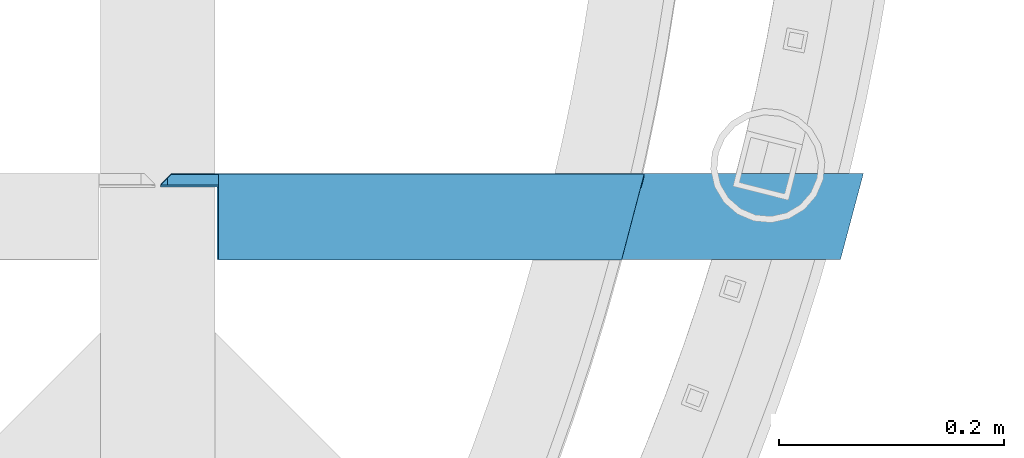
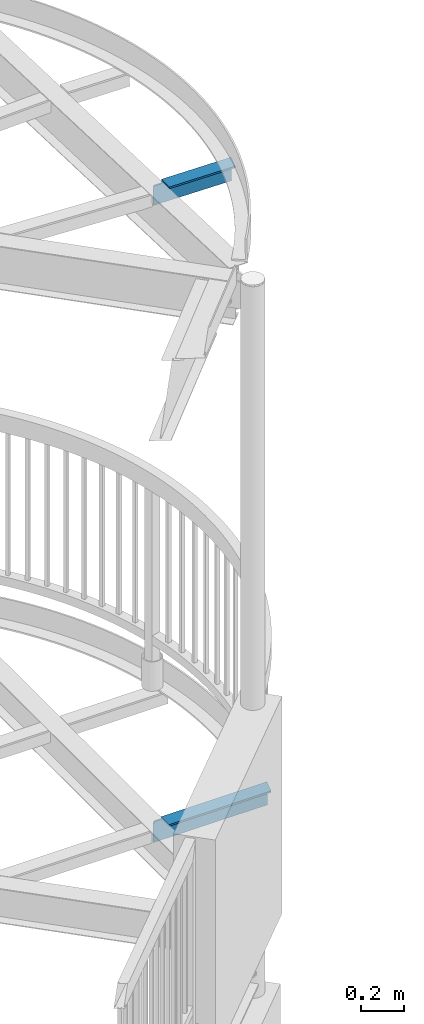
# One storey, part 525 of 975: 2 beams.
"""IFC2X3 building model written with IfcOpenShell, lengths in millimetres."""

import ifcopenshell
import ifcopenshell.guid

model = None  # the IFC model being written
_history = None  # IfcOwnerHistory: only IFC2X3 demands one
_inside = {}  # id of a spatial element -> (the spatial element, [elements in it])
_under = {}  # id of a project, library or spatial element -> (it, [spatial elements below it])
_declared = {}  # id of a project -> (the project, [libraries it declares])
_typed = {}  # id of a type object -> (the type object, [elements of that type])
_made_of = {}  # id of a material, layer set ... -> (it, [elements and type objects made of it])


def new_model(schema):
    """Start an empty IFC model of exactly this schema.

    Asked for "IFC4X3", IfcOpenShell would pick the latest addendum, in which some entities
    have other attributes; the version numbers below select the first issue.
    IFC2X3 requires an IfcOwnerHistory on every rooted entity: one is made here for all.
    """
    global model, _history
    if schema == "IFC4X3":
        model = ifcopenshell.file(schema_version=(4, 3, 0, 0))
    else:
        model = ifcopenshell.file(schema=schema)
    _inside.clear()
    _under.clear()
    _declared.clear()
    _typed.clear()
    _made_of.clear()
    _history = None
    if model.schema == "IFC2X3":
        org = make("IfcOrganization", Name="unknown")
        user = make(
            "IfcPersonAndOrganization",
            ThePerson=make("IfcPerson", FamilyName="unknown"),
            TheOrganization=org,
        )
        app = make(
            "IfcApplication",
            ApplicationDeveloper=org,
            Version="unknown",
            ApplicationFullName="unknown",
            ApplicationIdentifier="unknown",
        )
        _history = make(
            "IfcOwnerHistory",
            OwningUser=user,
            OwningApplication=app,
            ChangeAction="ADDED",
            CreationDate=0,
        )
    return model


def make(cls, **values):
    """One entity of the class cls with the attributes given. An attribute that is None is left unset."""
    return model.create_entity(
        cls, **{name: value for name, value in values.items() if value is not None}
    )


def rooted(cls, **values):
    """An entity with a GlobalId (a new one), such as an element, a storey or a relation."""
    return make(cls, GlobalId=ifcopenshell.guid.new(), OwnerHistory=_history, **values)


def si_unit(unit_type, name, prefix=None):
    """IfcSIUnit, for example si_unit("LENGTHUNIT", "METRE", prefix="MILLI")."""
    return make("IfcSIUnit", UnitType=unit_type, Prefix=prefix, Name=name)


def assignment(units):
    """IfcUnitAssignment: the units of a project."""
    return None if units is None else make("IfcUnitAssignment", Units=units)


def point(xyz):
    """IfcCartesianPoint."""
    return None if xyz is None else make("IfcCartesianPoint", Coordinates=xyz)


def direction(xyz):
    """IfcDirection."""
    return None if xyz is None else make("IfcDirection", DirectionRatios=xyz)


def frame(location, z_axis=None, x_axis=None):
    """IfcAxis2Placement3D, a coordinate frame: its origin and axes. An axis left out is left unset."""
    return make(
        "IfcAxis2Placement3D",
        Location=point(location),
        Axis=direction(z_axis),
        RefDirection=direction(x_axis),
    )


def origin_with_axes():
    """The frame at (0, 0, 0) with the z axis (0, 0, 1) and the x axis (1, 0, 0) written out."""
    return frame((0.0, 0.0, 0.0), z_axis=(0.0, 0.0, 1.0), x_axis=(1.0, 0.0, 0.0))


def place(relative_to, where):
    """IfcLocalPlacement: puts the frame where relative to a parent placement (None: the world)."""
    return make(
        "IfcLocalPlacement", PlacementRelTo=relative_to, RelativePlacement=where
    )


def context(
    kind, dimensions, precision=None, world=None, true_north=None, identifier=None
):
    """IfcGeometricRepresentationContext, for example the 3D "Model" context."""
    return make(
        "IfcGeometricRepresentationContext",
        ContextIdentifier=identifier,
        ContextType=kind,
        CoordinateSpaceDimension=dimensions,
        Precision=precision,
        WorldCoordinateSystem=world,
        TrueNorth=true_north,
    )


def subcontext(parent, identifier, kind, view, scale=None):
    """IfcGeometricRepresentationSubContext, for example "Body" below "Model"."""
    return make(
        "IfcGeometricRepresentationSubContext",
        ContextIdentifier=identifier,
        ContextType=kind,
        ParentContext=parent,
        TargetScale=scale,
        TargetView=view,
    )


def project(units=None, contexts=None):
    """IfcProject with its units and contexts."""
    return rooted(
        "IfcProject",
        Name="project",
        RepresentationContexts=contexts,
        UnitsInContext=assignment(units),
    )


def spatial(cls, under=None, at=None, **own):
    """A site, building, storey or space (cls), placed at a placement, below another one or the project."""
    s = rooted(cls, ObjectPlacement=at, **own)
    if under is not None:
        _under.setdefault(under.id(), (under, []))[1].append(s)
    return s


def faces_of(points, faces, orient=None, outer=None):
    """IfcFace entities. A face is a list of loops; a loop is a list of indices into points, from 0.

    orient and outer hold one flag for each loop. By default every Orientation is true, the
    first loop of a face is its IfcFaceOuterBound and the others are IfcFaceBound.
    """
    made = []
    for i, loops in enumerate(faces):
        bounds = []
        for j, loop in enumerate(loops):
            is_outer = j == 0 if outer is None else outer[i][j]
            bounds.append(
                make(
                    "IfcFaceOuterBound" if is_outer else "IfcFaceBound",
                    Bound=make("IfcPolyLoop", Polygon=[points[k] for k in loop]),
                    Orientation=True if orient is None else orient[i][j],
                )
            )
        made.append(make("IfcFace", Bounds=bounds))
    return made


def faceted_brep(points, faces, orient=None, outer=None, voids=None):
    """IfcFacetedBrep: a solid bounded by flat faces; with voids (closed shells), ...WithVoids."""
    shared = [point(p) for p in points]
    hull = make("IfcClosedShell", CfsFaces=faces_of(shared, faces, orient, outer))
    if voids is None:
        return make("IfcFacetedBrep", Outer=hull)
    return make(
        "IfcFacetedBrepWithVoids",
        Outer=hull,
        Voids=[
            make(cls, CfsFaces=faces_of(shared, fs, o, b)) for cls, fs, o, b in voids
        ],
    )


def shape(context_of_items, identifier, shape_type, items):
    """IfcShapeRepresentation: the items that make up one representation, for example the "Body"."""
    return make(
        "IfcShapeRepresentation",
        ContextOfItems=context_of_items,
        RepresentationIdentifier=identifier,
        RepresentationType=shape_type,
        Items=items,
    )


def material(Name=None, Category=None):
    """IfcMaterial."""
    return make("IfcMaterial", Name=Name, Category=Category)


def made_of(thing, what):
    """Note that an element or type object is made of a material, layer set ...; save() writes the relation."""
    if what is not None:
        _made_of.setdefault(what.id(), (what, []))[1].append(thing)
    return thing


def type_object(cls, material=None, **own):
    """A type object (cls), such as IfcWallType, which elements share."""
    return made_of(rooted(cls, **own), material)


def element(
    cls,
    number,
    at=None,
    inside=None,
    cuts=None,
    type_object=None,
    material=None,
    context=None,
    identifier="Body",
    shape_type=None,
    held_by="IfcProductDefinitionShape",
    body=None,
    shapes=None,
    **own,
):
    """One element of the class cls, such as IfcWall. Its Tag is "e" and its number.

    at: its placement. inside: the storey or other place that contains it. cuts: it is an
    opening in that element (IfcRelVoidsElement). A single representation is given by context,
    identifier, shape_type and body (its items); several are given by shapes. held_by: the class
    of the entity that holds the representations. save() writes the other relations.
    """
    e = rooted(cls, Tag="e%d" % number, ObjectPlacement=at, **own)
    if body is not None:
        shapes = [shape(context, identifier, shape_type, body)]
    if shapes is not None:
        e.Representation = make(held_by, Representations=shapes)
    if inside is not None:
        _inside.setdefault(inside.id(), (inside, []))[1].append(e)
    if cuts is not None:
        rooted(
            "IfcRelVoidsElement", RelatingBuildingElement=cuts, RelatedOpeningElement=e
        )
    if type_object is not None:
        _typed.setdefault(type_object.id(), (type_object, []))[1].append(e)
    return made_of(e, material)


def aggregate(whole, parts):
    """IfcRelAggregates: a whole, such as a stair, and the parts it consists of."""
    return rooted("IfcRelAggregates", RelatingObject=whole, RelatedObjects=parts)


def save(model, path):
    """Write the relations noted so far, then the file.

    IfcRelAggregates (storeys below a building ...), IfcRelContainedInSpatialStructure (elements
    in a storey), IfcRelDefinesByType, IfcRelAssociatesMaterial and IfcRelDeclares: one each for
    every whole, place, type object, material and project.
    """
    for whole, parts in _under.values():
        aggregate(whole, parts)
    for where, things in _inside.values():
        rooted(
            "IfcRelContainedInSpatialStructure",
            RelatedElements=things,
            RelatingStructure=where,
        )
    for kind, things in _typed.values():
        rooted("IfcRelDefinesByType", RelatedObjects=things, RelatingType=kind)
    for what, things in _made_of.values():
        rooted("IfcRelAssociatesMaterial", RelatedObjects=things, RelatingMaterial=what)
    for by, libraries in _declared.values():
        rooted("IfcRelDeclares", RelatingContext=by, RelatedDefinitions=libraries)
    model.write(path)


model = new_model("IFC2X3")

# Units and contexts
model_context = context("Model", 3, precision=1e-05, world=origin_with_axes())
body_context = subcontext(model_context, "Body", "Model", "MODEL_VIEW")
ifc_project = project(units=[si_unit("LENGTHUNIT", "METRE", prefix="MILLI"), si_unit("AREAUNIT", "SQUARE_METRE"), si_unit("VOLUMEUNIT", "CUBIC_METRE"), si_unit("MASSUNIT", "GRAM", prefix="KILO"), si_unit("TIMEUNIT", "SECOND"), si_unit("PLANEANGLEUNIT", "RADIAN"), si_unit("SOLIDANGLEUNIT", "STERADIAN"), si_unit("THERMODYNAMICTEMPERATUREUNIT", "DEGREE_CELSIUS"), si_unit("LUMINOUSINTENSITYUNIT", "LUMEN")], contexts=[model_context])

# Site, building, storey
site_placement = place(None, origin_with_axes())
site = spatial("IfcSite", under=ifc_project, at=site_placement, CompositionType="ELEMENT")
building_placement = place(site_placement, origin_with_axes())
building = spatial("IfcBuilding", under=site, at=building_placement, Name="Undefined", CompositionType="ELEMENT")
storey_placement = place(building_placement, origin_with_axes())
storey = spatial("IfcBuildingStorey", under=building, at=storey_placement, Name="Undefined", CompositionType="ELEMENT", Elevation=0.0)

# Beams
ifc_material = material(Name="STEEL/A36")
beam_type = type_object("IfcBeamType", Name="L5X3X3/8", PredefinedType="NOTDEFINED")
beam_1_placement = place(storey_placement, frame((36163.6763496532, 11155.2515974381, 3873.5), z_axis=(0.0, 0.0, -1.0), x_axis=(-0.999999999999998, 6.90000001668524e-08, 0.0)))
element("IfcBeam", 1, at=beam_1_placement, inside=storey, type_object=beam_type, material=ifc_material, Name="ANGLE", ObjectType="L5X3X3/8", context=body_context, shape_type="Brep", body=[
    faceted_brep([(623.52009843519, 28.5749997057192, 63.4999984741212), (623.520098140936, 28.5750000000007, -41.2750001907348), (613.995098140935, 38.1000000000004, -50.8000001907362), (613.995098140935, 38.1000000000004, 63.5), (20.3317535649257, -38.1000000000004, -53.9749999999999), (20.3317535649257, -38.1000000000004, -63.5), (573.513849666815, -38.1000000000004, -63.5), (573.513849666815, -38.1000000000004, -53.9749999999999), (5.0931703299284e-11, 38.0999999999999, -63.5000000000255), (573.513849666815, 38.1000000000004, -63.5), (573.513849666815, 28.5750000000007, -53.9749999999999), (573.513849666815, 38.1000000000004, -53.9749999999999), (610.820098331671, 38.1000000000004, -53.9749999999999), (610.820098331671, 28.5750000000007, -53.9749999999999), (2.54146919561754, 28.5750000000007, -53.9749999999999), (2.54146919561754, 28.5750000000007, 63.5), (-4.72937244921923e-11, 38.0999999999999, 63.5000000000182)], [[[0, 1, 2, 3]], [[4, 5, 6, 7]], [[5, 8, 9, 6]], [[10, 11, 12, 13]], [[7, 6, 9, 11, 10]], [[14, 4, 7, 10]], [[5, 4, 14, 15, 16, 8]], [[16, 15, 0, 3]], [[12, 11, 9, 8, 16, 3, 2]], [[13, 12, 2, 1]], [[15, 14, 10, 13, 1, 0]]]),
])
beam_2_placement = place(storey_placement, frame((35868.7693707416, 11153.7321245128, 7524.89894022435), z_axis=(-0.0143565385619149, -0.0174506080076553, -0.999744650438642), x_axis=(-0.999896939589536, 0.000250555999896144, 0.0143543519941075)))
element("IfcBeam", 2, at=beam_2_placement, inside=storey, type_object=beam_type, material=ifc_material, Name="ANGLE", ObjectType="L5X3X3/8", context=body_context, shape_type="Brep", body=[
    faceted_brep([(-79.6043233385353, -38.1000000000859, -53.9749999999767), (-79.4675632157887, -38.1000000000877, -63.4999999999745), (278.134675619607, -38.0999999998603, -63.5000000000746), (277.99791549526, -38.0999999998567, -53.9750000000749), (-99.487759000549, 38.0999999999531, -63.4999999999527), (278.134675608235, 38.1000000001914, -63.5000000000582), (277.997915485306, 28.5750000001881, -53.9750000000622), (277.869168557991, 38.100000000195, -45.008099173594), (277.869168559424, 28.5750000001899, -45.0080991768627), (-97.1219946502024, 28.5749999999498, -53.9749999999585), (-98.8087028307855, 28.5749999999662, 63.5000000000218), (-101.311227303879, 38.0999999999713, 63.5000000000246), (318.209275315501, 38.1000000002387, 63.4999999999081), (319.758600970905, 38.1000000002223, -44.4066499363871), (322.98163191104, 28.5750000002172, -44.3603736024488), (322.981631914343, 34.8766369000623, -44.3603736002278), (329.184912349301, 28.5749997520652, -37.4648374813314), (327.735257068474, 28.5750000002408, 63.4999999999036)], [[[0, 1, 2, 3]], [[1, 4, 5, 2]], [[6, 3, 2, 5, 7, 8]], [[9, 0, 3, 6]], [[1, 0, 9, 10, 11, 4]], [[7, 5, 4, 11, 12, 13]], [[14, 8, 7, 13, 15]], [[14, 15, 16]], [[10, 9, 6, 8, 14, 16, 17]], [[11, 10, 17, 12]], [[16, 15, 13, 12, 17]]]),
])

save(model, "model.ifc")
